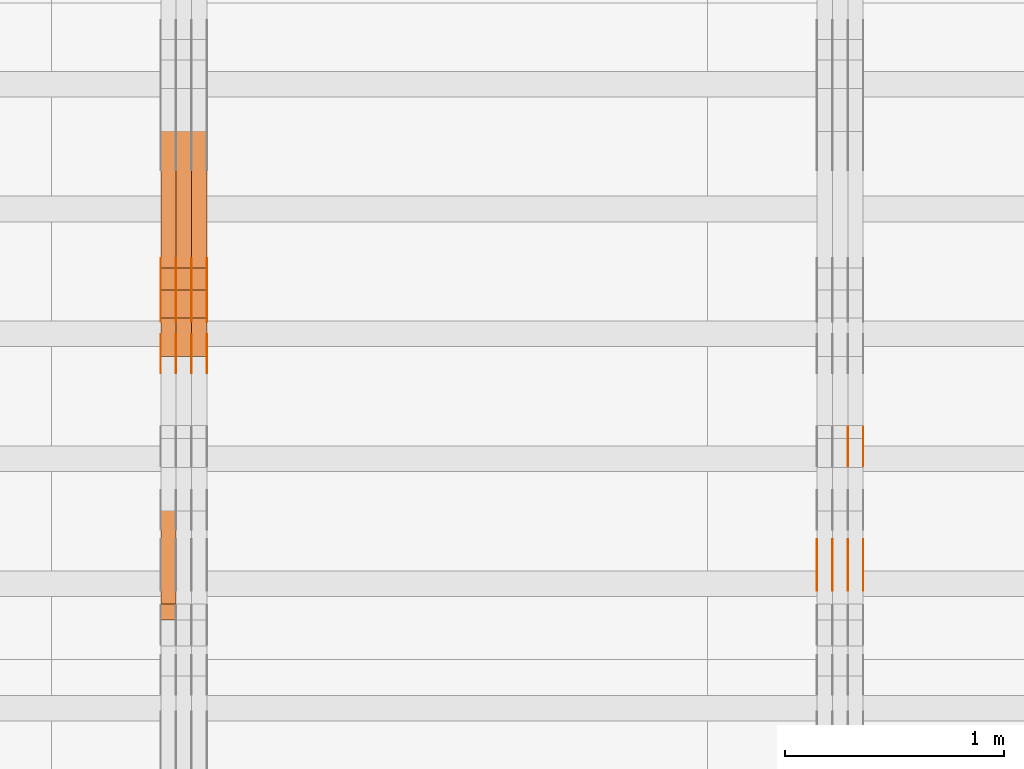
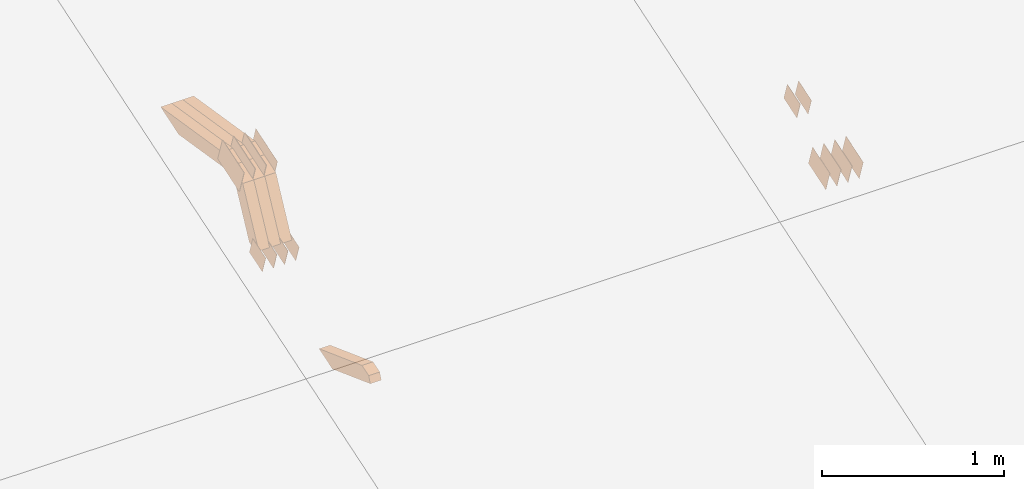
# One storey, part 136 of 385: 28 proxies.
"""IFC2X3 building model written with IfcOpenShell, lengths in millimetres."""

from ifc_helpers import new_model, entity, si_unit, converted_unit, derived_unit, direction, frame, origin, place, context, subcontext, project, spatial, polyline, outline, extrude, source, transform, mapped, material, type_object, type_shapes, element, save


model = new_model("IFC2X3")

# Units and contexts
model_context = context("Model", 3, precision=0.01, world=origin(), true_north=direction((6.12303176911189e-17, 1.0)))
body_context = subcontext(model_context, "Body", "Model", "MODEL_VIEW")
ifc_project = project(units=[si_unit("LENGTHUNIT", "METRE", prefix="MILLI"), si_unit("AREAUNIT", "SQUARE_METRE"), si_unit("VOLUMEUNIT", "CUBIC_METRE"), converted_unit("PLANEANGLEUNIT", "DEGREE", entity("IfcRatioMeasure", 0.0174532925199433), si_unit("PLANEANGLEUNIT", "RADIAN"), dimensions=[0, 0, 0, 0, 0, 0, 0]), si_unit("MASSUNIT", "GRAM", prefix="KILO"), derived_unit("MASSDENSITYUNIT", [(si_unit("MASSUNIT", "GRAM", prefix="KILO"), 1), (si_unit("LENGTHUNIT", "METRE"), -3)]), si_unit("TIMEUNIT", "SECOND"), si_unit("FREQUENCYUNIT", "HERTZ"), si_unit("THERMODYNAMICTEMPERATUREUNIT", "DEGREE_CELSIUS"), derived_unit("THERMALTRANSMITTANCEUNIT", [(si_unit("MASSUNIT", "GRAM", prefix="KILO"), 1), (si_unit("THERMODYNAMICTEMPERATUREUNIT", "KELVIN"), -1), (si_unit("TIMEUNIT", "SECOND"), -3)]), derived_unit("VOLUMETRICFLOWRATEUNIT", [(si_unit("LENGTHUNIT", "METRE"), 3), (si_unit("TIMEUNIT", "SECOND"), -1)]), si_unit("ELECTRICCURRENTUNIT", "AMPERE"), si_unit("ELECTRICVOLTAGEUNIT", "VOLT"), si_unit("POWERUNIT", "WATT"), si_unit("FORCEUNIT", "NEWTON", prefix="KILO"), si_unit("ILLUMINANCEUNIT", "LUX"), si_unit("LUMINOUSFLUXUNIT", "LUMEN"), si_unit("LUMINOUSINTENSITYUNIT", "CANDELA"), derived_unit("USERDEFINED", [(si_unit("MASSUNIT", "GRAM", prefix="KILO"), -1), (si_unit("LENGTHUNIT", "METRE"), -2), (si_unit("TIMEUNIT", "SECOND"), 3), (si_unit("LUMINOUSFLUXUNIT", "LUMEN"), 1)]), derived_unit("LINEARVELOCITYUNIT", [(si_unit("LENGTHUNIT", "METRE"), 1), (si_unit("TIMEUNIT", "SECOND"), -1)]), si_unit("PRESSUREUNIT", "PASCAL"), derived_unit("USERDEFINED", [(si_unit("LENGTHUNIT", "METRE"), -2), (si_unit("MASSUNIT", "GRAM", prefix="KILO"), 1), (si_unit("TIMEUNIT", "SECOND"), -2)])], contexts=[model_context])

# Site, building, storey
site_placement = place(None, origin())
site = spatial("IfcSite", under=ifc_project, at=site_placement, CompositionType="ELEMENT")
building_placement = place(site_placement, origin())
building = spatial("IfcBuilding", under=site, at=building_placement, CompositionType="ELEMENT")
storey_placement = place(building_placement, origin())
storey = spatial("IfcBuildingStorey", under=building, at=storey_placement, Name="Default", CompositionType="ELEMENT", Elevation=0.0)

# Proxies
ifc_material_1 = material(Name="IfcSurfaceStyle #349262")
building_element_proxy_type_1 = type_object("IfcBuildingElementProxyType", PredefinedType="NOTDEFINED", material=ifc_material_1)
shared_shape_1 = source(origin(), body_context, "Body", "SweptSolid", [
    extrude(outline(polyline([(-99.999644645517, -72.0000317581407), (100.000028485991, -72.0000317581407), (99.999644645517, 72.0000317581407), (-100.000028485991, 72.0000317581407), (-99.999644645517, -72.0000317581407)])), frame((100.000028485991, 72.0000317581407, 0.0), z_axis=(0.0, 0.0, 1.0), x_axis=(-1.0, 0.0, 0.0)), (0.0, 0.0, 1.0), 1.3),
])
type_shapes(building_element_proxy_type_1, [shared_shape_1])
proxy_1_placement = place(building_placement, frame((27386.3, 9012.6304394324, 2546.30522609783), z_axis=(-1.0, 0.0, 0.0), x_axis=(0.0, 0.951056516295154, 0.309016994374948)))
element("IfcBuildingElementProxy", 1, at=proxy_1_placement, inside=storey, type_object=building_element_proxy_type_1, material=ifc_material_1, context=body_context, shape_type="MappedRepresentation", body=[
    mapped(shared_shape_1, transform((0.0, 0.0, 0.0), scale=1.0)),
])
ifc_material_2 = material(Name="IfcSurfaceStyle #349205")
building_element_proxy_type_2 = type_object("IfcBuildingElementProxyType", PredefinedType="NOTDEFINED", material=ifc_material_2)
shared_shape_2 = source(origin(), body_context, "Body", "SweptSolid", [
    extrude(outline(polyline([(-99.999644645517, -72.0000317581407), (100.000028485991, -72.0000317581407), (99.999644645517, 72.0000317581407), (-100.000028485991, 72.0000317581407), (-99.999644645517, -72.0000317581407)])), frame((100.000028485991, 72.0000317581407, 0.0), z_axis=(0.0, 0.0, 1.0), x_axis=(-1.0, 0.0, 0.0)), (0.0, 0.0, 1.0), 1.3),
])
type_shapes(building_element_proxy_type_2, [shared_shape_2])
proxy_2_placement = place(building_placement, frame((27315.0, 9012.6304394324, 2546.30522609783), z_axis=(-1.0, 0.0, 0.0), x_axis=(0.0, 0.951056516295154, 0.309016994374948)))
element("IfcBuildingElementProxy", 2, at=proxy_2_placement, inside=storey, type_object=building_element_proxy_type_2, material=ifc_material_2, context=body_context, shape_type="MappedRepresentation", body=[
    mapped(shared_shape_2, transform((0.0, 0.0, 0.0), scale=1.0)),
])
ifc_material_3 = material(Name="IfcSurfaceStyle #349148")
building_element_proxy_type_3 = type_object("IfcBuildingElementProxyType", PredefinedType="NOTDEFINED", material=ifc_material_3)
shared_shape_3 = source(origin(), body_context, "Body", "SweptSolid", [
    extrude(outline(polyline([(-99.999644645517, -72.0000317581407), (100.000028485991, -72.0000317581407), (99.999644645517, 72.0000317581407), (-100.000028485991, 72.0000317581407), (-99.999644645517, -72.0000317581407)])), frame((100.000028485991, 72.0000317581407, 0.0), z_axis=(0.0, 0.0, 1.0), x_axis=(-1.0, 0.0, 0.0)), (0.0, 0.0, 1.0), 1.3),
])
type_shapes(building_element_proxy_type_3, [shared_shape_3])
proxy_3_placement = place(building_placement, frame((27316.3, 9012.6304394324, 2546.30522609783), z_axis=(-1.0, 0.0, 0.0), x_axis=(0.0, 0.951056516295154, 0.309016994374948)))
element("IfcBuildingElementProxy", 3, at=proxy_3_placement, inside=storey, type_object=building_element_proxy_type_3, material=ifc_material_3, context=body_context, shape_type="MappedRepresentation", body=[
    mapped(shared_shape_3, transform((0.0, 0.0, 0.0), scale=1.0)),
])
ifc_material_4 = material(Name="IfcSurfaceStyle #349091")
building_element_proxy_type_4 = type_object("IfcBuildingElementProxyType", PredefinedType="NOTDEFINED", material=ifc_material_4)
shared_shape_4 = source(origin(), body_context, "Body", "SweptSolid", [
    extrude(outline(polyline([(-99.999644645517, -72.0000317581407), (100.000028485991, -72.0000317581407), (99.999644645517, 72.0000317581407), (-100.000028485991, 72.0000317581407), (-99.999644645517, -72.0000317581407)])), frame((100.000028485991, 72.0000317581407, 0.0), z_axis=(0.0, 0.0, 1.0), x_axis=(-1.0, 0.0, 0.0)), (0.0, 0.0, 1.0), 1.29999999999998),
])
type_shapes(building_element_proxy_type_4, [shared_shape_4])
proxy_4_placement = place(building_placement, frame((27245.0, 9012.6304394324, 2546.30522609783), z_axis=(-1.0, 0.0, 0.0), x_axis=(0.0, 0.951056516295154, 0.309016994374948)))
element("IfcBuildingElementProxy", 4, at=proxy_4_placement, inside=storey, type_object=building_element_proxy_type_4, material=ifc_material_4, context=body_context, shape_type="MappedRepresentation", body=[
    mapped(shared_shape_4, transform((0.0, 0.0, 0.0), scale=1.0)),
])
ifc_material_5 = material(Name="IfcSurfaceStyle #349034")
building_element_proxy_type_5 = type_object("IfcBuildingElementProxyType", PredefinedType="NOTDEFINED", material=ifc_material_5)
shared_shape_5 = source(origin(), body_context, "Body", "SweptSolid", [
    extrude(outline(polyline([(-99.999644645517, -72.0000317581407), (100.000028485991, -72.0000317581407), (99.999644645517, 72.0000317581407), (-100.000028485991, 72.0000317581407), (-99.999644645517, -72.0000317581407)])), frame((100.000028485991, 72.0000317581407, 0.0), z_axis=(0.0, 0.0, 1.0), x_axis=(-1.0, 0.0, 0.0)), (0.0, 0.0, 1.0), 1.29999999999998),
])
type_shapes(building_element_proxy_type_5, [shared_shape_5])
proxy_5_placement = place(building_placement, frame((27246.3, 9012.6304394324, 2546.30522609783), z_axis=(-1.0, 0.0, 0.0), x_axis=(0.0, 0.951056516295154, 0.309016994374948)))
element("IfcBuildingElementProxy", 5, at=proxy_5_placement, inside=storey, type_object=building_element_proxy_type_5, material=ifc_material_5, context=body_context, shape_type="MappedRepresentation", body=[
    mapped(shared_shape_5, transform((0.0, 0.0, 0.0), scale=1.0)),
])
ifc_material_6 = material(Name="IfcSurfaceStyle #348977")
building_element_proxy_type_6 = type_object("IfcBuildingElementProxyType", PredefinedType="NOTDEFINED", material=ifc_material_6)
shared_shape_6 = source(origin(), body_context, "Body", "SweptSolid", [
    extrude(outline(polyline([(-99.999644645517, -72.0000317581407), (100.000028485991, -72.0000317581407), (99.999644645517, 72.0000317581407), (-100.000028485991, 72.0000317581407), (-99.999644645517, -72.0000317581407)])), frame((100.000028485991, 72.0000317581407, 0.0), z_axis=(0.0, 0.0, 1.0), x_axis=(-1.0, 0.0, 0.0)), (0.0, 0.0, 1.0), 1.29999999999999),
])
type_shapes(building_element_proxy_type_6, [shared_shape_6])
proxy_6_placement = place(building_placement, frame((27175.0, 9012.6304394324, 2546.30522609783), z_axis=(-1.0, 0.0, 0.0), x_axis=(0.0, 0.951056516295154, 0.309016994374948)))
element("IfcBuildingElementProxy", 6, at=proxy_6_placement, inside=storey, type_object=building_element_proxy_type_6, material=ifc_material_6, context=body_context, shape_type="MappedRepresentation", body=[
    mapped(shared_shape_6, transform((0.0, 0.0, 0.0), scale=1.0)),
])
ifc_material_7 = material(Name="IfcSurfaceStyle #348920")
building_element_proxy_type_7 = type_object("IfcBuildingElementProxyType", PredefinedType="NOTDEFINED", material=ifc_material_7)
shared_shape_7 = source(origin(), body_context, "Body", "SweptSolid", [
    extrude(outline(polyline([(-74.9998754286207, -60.0000016373506), (74.9998605591063, -60.0000016373506), (74.9998754286244, 60.0000016373506), (-74.9998605591099, 60.0000016373506), (-74.9998754286207, -60.0000016373506)])), frame((74.9998754286244, 60.0000016373506, 0.0), z_axis=(0.0, 0.0, 1.0), x_axis=(-1.0, 0.0, 0.0)), (0.0, 0.0, 1.0), 1.3),
])
type_shapes(building_element_proxy_type_7, [shared_shape_7])
proxy_7_placement = place(building_placement, frame((27386.3, 9580.89841427132, 2615.81135078741), z_axis=(-1.0, 0.0, 0.0), x_axis=(0.0, 0.951056516295154, 0.309016994374948)))
element("IfcBuildingElementProxy", 7, at=proxy_7_placement, inside=storey, type_object=building_element_proxy_type_7, material=ifc_material_7, context=body_context, shape_type="MappedRepresentation", body=[
    mapped(shared_shape_7, transform((0.0, 0.0, 0.0), scale=1.0)),
])
ifc_material_8 = material(Name="IfcSurfaceStyle #348863")
building_element_proxy_type_8 = type_object("IfcBuildingElementProxyType", PredefinedType="NOTDEFINED", material=ifc_material_8)
shared_shape_8 = source(origin(), body_context, "Body", "SweptSolid", [
    extrude(outline(polyline([(-74.9998754286207, -60.0000016373506), (74.9998605591063, -60.0000016373506), (74.9998754286244, 60.0000016373506), (-74.9998605591099, 60.0000016373506), (-74.9998754286207, -60.0000016373506)])), frame((74.9998754286244, 60.0000016373506, 0.0), z_axis=(0.0, 0.0, 1.0), x_axis=(-1.0, 0.0, 0.0)), (0.0, 0.0, 1.0), 1.3),
])
type_shapes(building_element_proxy_type_8, [shared_shape_8])
proxy_8_placement = place(building_placement, frame((27315.0, 9580.89841427132, 2615.81135078741), z_axis=(-1.0, 0.0, 0.0), x_axis=(0.0, 0.951056516295154, 0.309016994374948)))
element("IfcBuildingElementProxy", 8, at=proxy_8_placement, inside=storey, type_object=building_element_proxy_type_8, material=ifc_material_8, context=body_context, shape_type="MappedRepresentation", body=[
    mapped(shared_shape_8, transform((0.0, 0.0, 0.0), scale=1.0)),
])
ifc_material_9 = material(Name="IfcSurfaceStyle #348806")
building_element_proxy_type_9 = type_object("IfcBuildingElementProxyType", PredefinedType="NOTDEFINED", material=ifc_material_9)
shared_shape_9 = source(origin(), body_context, "Body", "SweptSolid", [
    extrude(outline(polyline([(-74.9998754286207, -60.0000016373506), (74.9998605591063, -60.0000016373506), (74.9998754286244, 60.0000016373506), (-74.9998605591099, 60.0000016373506), (-74.9998754286207, -60.0000016373506)])), frame((74.9998754286244, 60.0000016373506, 0.0), z_axis=(0.0, 0.0, 1.0), x_axis=(-1.0, 0.0, 0.0)), (0.0, 0.0, 1.0), 1.3),
])
type_shapes(building_element_proxy_type_9, [shared_shape_9])
proxy_9_placement = place(building_placement, frame((27316.3, 9580.89841427132, 2615.81135078741), z_axis=(-1.0, 0.0, 0.0), x_axis=(0.0, 0.951056516295154, 0.309016994374948)))
element("IfcBuildingElementProxy", 9, at=proxy_9_placement, inside=storey, type_object=building_element_proxy_type_9, material=ifc_material_9, context=body_context, shape_type="MappedRepresentation", body=[
    mapped(shared_shape_9, transform((0.0, 0.0, 0.0), scale=1.0)),
])
ifc_material_10 = material(Name="IfcSurfaceStyle #313120")
building_element_proxy_type_10 = type_object("IfcBuildingElementProxyType", PredefinedType="NOTDEFINED", material=ifc_material_10)
shared_shape_10 = source(origin(), body_context, "Body", "SweptSolid", [
    extrude(outline(polyline([(-124.999432723313, -83.9999457831645), (125.000177551971, -83.9999457831645), (124.999395001513, 83.9999457831646), (-125.000139830171, 83.9999457831645), (-124.999432723313, -83.9999457831645)])), frame((125.000177551971, 84.0001194377192, 0.0), z_axis=(0.0, 0.0, 1.0), x_axis=(-1.0, 0.0, 0.0)), (0.0, 0.0, 1.0), 1.3),
])
type_shapes(building_element_proxy_type_10, [shared_shape_10])
proxy_10_placement = place(building_placement, frame((24386.3, 10242.0968435406, 2855.88278137571), z_axis=(-1.0, 0.0, 0.0), x_axis=(0.0, 0.951056516295154, 0.309016994374948)))
element("IfcBuildingElementProxy", 10, at=proxy_10_placement, inside=storey, type_object=building_element_proxy_type_10, material=ifc_material_10, context=body_context, shape_type="MappedRepresentation", body=[
    mapped(shared_shape_10, transform((0.0, 0.0, 0.0), scale=1.0)),
])
ifc_material_11 = material(Name="IfcSurfaceStyle #313063")
building_element_proxy_type_11 = type_object("IfcBuildingElementProxyType", PredefinedType="NOTDEFINED", material=ifc_material_11)
shared_shape_11 = source(origin(), body_context, "Body", "SweptSolid", [
    extrude(outline(polyline([(-124.999432723313, -83.9999457831645), (125.000177551971, -83.9999457831645), (124.999395001513, 83.9999457831646), (-125.000139830171, 83.9999457831645), (-124.999432723313, -83.9999457831645)])), frame((125.000177551971, 84.0001194377192, 0.0), z_axis=(0.0, 0.0, 1.0), x_axis=(-1.0, 0.0, 0.0)), (0.0, 0.0, 1.0), 1.3),
])
type_shapes(building_element_proxy_type_11, [shared_shape_11])
proxy_11_placement = place(building_placement, frame((24315.0, 10242.0968435406, 2855.88278137571), z_axis=(-1.0, 0.0, 0.0), x_axis=(0.0, 0.951056516295154, 0.309016994374948)))
element("IfcBuildingElementProxy", 11, at=proxy_11_placement, inside=storey, type_object=building_element_proxy_type_11, material=ifc_material_11, context=body_context, shape_type="MappedRepresentation", body=[
    mapped(shared_shape_11, transform((0.0, 0.0, 0.0), scale=1.0)),
])
ifc_material_12 = material(Name="IfcSurfaceStyle #313006")
building_element_proxy_type_12 = type_object("IfcBuildingElementProxyType", PredefinedType="NOTDEFINED", material=ifc_material_12)
shared_shape_12 = source(origin(), body_context, "Body", "SweptSolid", [
    extrude(outline(polyline([(-124.999432723313, -83.9999457831645), (125.000177551971, -83.9999457831645), (124.999395001513, 83.9999457831646), (-125.000139830171, 83.9999457831645), (-124.999432723313, -83.9999457831645)])), frame((125.000177551971, 84.0001194377192, 0.0), z_axis=(0.0, 0.0, 1.0), x_axis=(-1.0, 0.0, 0.0)), (0.0, 0.0, 1.0), 1.3),
])
type_shapes(building_element_proxy_type_12, [shared_shape_12])
proxy_12_placement = place(building_placement, frame((24316.3, 10242.0968435406, 2855.88278137571), z_axis=(-1.0, 0.0, 0.0), x_axis=(0.0, 0.951056516295154, 0.309016994374948)))
element("IfcBuildingElementProxy", 12, at=proxy_12_placement, inside=storey, type_object=building_element_proxy_type_12, material=ifc_material_12, context=body_context, shape_type="MappedRepresentation", body=[
    mapped(shared_shape_12, transform((0.0, 0.0, 0.0), scale=1.0)),
])
ifc_material_13 = material(Name="IfcSurfaceStyle #312949")
building_element_proxy_type_13 = type_object("IfcBuildingElementProxyType", PredefinedType="NOTDEFINED", material=ifc_material_13)
shared_shape_13 = source(origin(), body_context, "Body", "SweptSolid", [
    extrude(outline(polyline([(-124.999432723313, -83.9999457831645), (125.000177551971, -83.9999457831645), (124.999395001513, 83.9999457831646), (-125.000139830171, 83.9999457831645), (-124.999432723313, -83.9999457831645)])), frame((125.000177551971, 84.0001194377192, 0.0), z_axis=(0.0, 0.0, 1.0), x_axis=(-1.0, 0.0, 0.0)), (0.0, 0.0, 1.0), 1.29999999999998),
])
type_shapes(building_element_proxy_type_13, [shared_shape_13])
proxy_13_placement = place(building_placement, frame((24245.0, 10242.0968435406, 2855.88278137571), z_axis=(-1.0, 0.0, 0.0), x_axis=(0.0, 0.951056516295154, 0.309016994374948)))
element("IfcBuildingElementProxy", 13, at=proxy_13_placement, inside=storey, type_object=building_element_proxy_type_13, material=ifc_material_13, context=body_context, shape_type="MappedRepresentation", body=[
    mapped(shared_shape_13, transform((0.0, 0.0, 0.0), scale=1.0)),
])
ifc_material_14 = material(Name="IfcSurfaceStyle #312892")
building_element_proxy_type_14 = type_object("IfcBuildingElementProxyType", PredefinedType="NOTDEFINED", material=ifc_material_14)
shared_shape_14 = source(origin(), body_context, "Body", "SweptSolid", [
    extrude(outline(polyline([(-124.999432723313, -83.9999457831645), (125.000177551971, -83.9999457831645), (124.999395001513, 83.9999457831646), (-125.000139830171, 83.9999457831645), (-124.999432723313, -83.9999457831645)])), frame((125.000177551971, 84.0001194377192, 0.0), z_axis=(0.0, 0.0, 1.0), x_axis=(-1.0, 0.0, 0.0)), (0.0, 0.0, 1.0), 1.29999999999998),
])
type_shapes(building_element_proxy_type_14, [shared_shape_14])
proxy_14_placement = place(building_placement, frame((24246.3, 10242.0968435406, 2855.88278137571), z_axis=(-1.0, 0.0, 0.0), x_axis=(0.0, 0.951056516295154, 0.309016994374948)))
element("IfcBuildingElementProxy", 14, at=proxy_14_placement, inside=storey, type_object=building_element_proxy_type_14, material=ifc_material_14, context=body_context, shape_type="MappedRepresentation", body=[
    mapped(shared_shape_14, transform((0.0, 0.0, 0.0), scale=1.0)),
])
ifc_material_15 = material(Name="IfcSurfaceStyle #312835")
building_element_proxy_type_15 = type_object("IfcBuildingElementProxyType", PredefinedType="NOTDEFINED", material=ifc_material_15)
shared_shape_15 = source(origin(), body_context, "Body", "SweptSolid", [
    extrude(outline(polyline([(-124.999432723313, -83.9999457831645), (125.000177551971, -83.9999457831645), (124.999395001513, 83.9999457831646), (-125.000139830171, 83.9999457831645), (-124.999432723313, -83.9999457831645)])), frame((125.000177551971, 84.0001194377192, 0.0), z_axis=(0.0, 0.0, 1.0), x_axis=(-1.0, 0.0, 0.0)), (0.0, 0.0, 1.0), 1.29999999999998),
])
type_shapes(building_element_proxy_type_15, [shared_shape_15])
proxy_15_placement = place(building_placement, frame((24175.0, 10242.0968435406, 2855.88278137571), z_axis=(-1.0, 0.0, 0.0), x_axis=(0.0, 0.951056516295154, 0.309016994374948)))
element("IfcBuildingElementProxy", 15, at=proxy_15_placement, inside=storey, type_object=building_element_proxy_type_15, material=ifc_material_15, context=body_context, shape_type="MappedRepresentation", body=[
    mapped(shared_shape_15, transform((0.0, 0.0, 0.0), scale=1.0)),
])
ifc_material_16 = material(Name="IfcSurfaceStyle #311410")
building_element_proxy_type_16 = type_object("IfcBuildingElementProxyType", PredefinedType="NOTDEFINED", material=ifc_material_16)
shared_shape_16 = source(origin(), body_context, "Body", "SweptSolid", [
    extrude(outline(polyline([(-74.9998754286189, -60.0000016373433), (74.9998605591118, -60.0000016373433), (74.9998754286189, 60.0000016373433), (-74.9998605591118, 60.0000016373433), (-74.9998754286189, -60.0000016373433)])), frame((74.9999131819004, 60.0000016373433, 0.0), z_axis=(0.0, 0.0, 1.0), x_axis=(-1.0, 0.0, 0.0)), (0.0, 0.0, 1.0), 1.3),
])
type_shapes(building_element_proxy_type_16, [shared_shape_16])
proxy_16_placement = place(building_placement, frame((24386.3, 10004.8612689908, 2426.87628052724), z_axis=(-1.0, 0.0, 0.0), x_axis=(0.0, 0.951056516295124, 0.309016994375039)))
element("IfcBuildingElementProxy", 16, at=proxy_16_placement, inside=storey, type_object=building_element_proxy_type_16, material=ifc_material_16, context=body_context, shape_type="MappedRepresentation", body=[
    mapped(shared_shape_16, transform((0.0, 0.0, 0.0), scale=1.0)),
])
ifc_material_17 = material(Name="IfcSurfaceStyle #311353")
building_element_proxy_type_17 = type_object("IfcBuildingElementProxyType", PredefinedType="NOTDEFINED", material=ifc_material_17)
shared_shape_17 = source(origin(), body_context, "Body", "SweptSolid", [
    extrude(outline(polyline([(-74.9998754286189, -60.0000016373433), (74.9998605591118, -60.0000016373433), (74.9998754286189, 60.0000016373433), (-74.9998605591118, 60.0000016373433), (-74.9998754286189, -60.0000016373433)])), frame((74.9999131819004, 60.0000016373433, 0.0), z_axis=(0.0, 0.0, 1.0), x_axis=(-1.0, 0.0, 0.0)), (0.0, 0.0, 1.0), 1.3),
])
type_shapes(building_element_proxy_type_17, [shared_shape_17])
proxy_17_placement = place(building_placement, frame((24315.0, 10004.8612689908, 2426.87628052724), z_axis=(-1.0, 0.0, 0.0), x_axis=(0.0, 0.951056516295124, 0.309016994375039)))
element("IfcBuildingElementProxy", 17, at=proxy_17_placement, inside=storey, type_object=building_element_proxy_type_17, material=ifc_material_17, context=body_context, shape_type="MappedRepresentation", body=[
    mapped(shared_shape_17, transform((0.0, 0.0, 0.0), scale=1.0)),
])
ifc_material_18 = material(Name="IfcSurfaceStyle #311296")
building_element_proxy_type_18 = type_object("IfcBuildingElementProxyType", PredefinedType="NOTDEFINED", material=ifc_material_18)
shared_shape_18 = source(origin(), body_context, "Body", "SweptSolid", [
    extrude(outline(polyline([(-74.9998754286189, -60.0000016373433), (74.9998605591118, -60.0000016373433), (74.9998754286189, 60.0000016373433), (-74.9998605591118, 60.0000016373433), (-74.9998754286189, -60.0000016373433)])), frame((74.9999131819004, 60.0000016373433, 0.0), z_axis=(0.0, 0.0, 1.0), x_axis=(-1.0, 0.0, 0.0)), (0.0, 0.0, 1.0), 1.3),
])
type_shapes(building_element_proxy_type_18, [shared_shape_18])
proxy_18_placement = place(building_placement, frame((24316.3, 10004.8612689908, 2426.87628052724), z_axis=(-1.0, 0.0, 0.0), x_axis=(0.0, 0.951056516295124, 0.309016994375039)))
element("IfcBuildingElementProxy", 18, at=proxy_18_placement, inside=storey, type_object=building_element_proxy_type_18, material=ifc_material_18, context=body_context, shape_type="MappedRepresentation", body=[
    mapped(shared_shape_18, transform((0.0, 0.0, 0.0), scale=1.0)),
])
ifc_material_19 = material(Name="IfcSurfaceStyle #311239")
building_element_proxy_type_19 = type_object("IfcBuildingElementProxyType", PredefinedType="NOTDEFINED", material=ifc_material_19)
shared_shape_19 = source(origin(), body_context, "Body", "SweptSolid", [
    extrude(outline(polyline([(-74.9998754286189, -60.0000016373433), (74.9998605591118, -60.0000016373433), (74.9998754286189, 60.0000016373433), (-74.9998605591118, 60.0000016373433), (-74.9998754286189, -60.0000016373433)])), frame((74.9999131819004, 60.0000016373433, 0.0), z_axis=(0.0, 0.0, 1.0), x_axis=(-1.0, 0.0, 0.0)), (0.0, 0.0, 1.0), 1.29999999999999),
])
type_shapes(building_element_proxy_type_19, [shared_shape_19])
proxy_19_placement = place(building_placement, frame((24245.0, 10004.8612689908, 2426.87628052724), z_axis=(-1.0, 0.0, 0.0), x_axis=(0.0, 0.951056516295124, 0.309016994375039)))
element("IfcBuildingElementProxy", 19, at=proxy_19_placement, inside=storey, type_object=building_element_proxy_type_19, material=ifc_material_19, context=body_context, shape_type="MappedRepresentation", body=[
    mapped(shared_shape_19, transform((0.0, 0.0, 0.0), scale=1.0)),
])
ifc_material_20 = material(Name="IfcSurfaceStyle #311182")
building_element_proxy_type_20 = type_object("IfcBuildingElementProxyType", PredefinedType="NOTDEFINED", material=ifc_material_20)
shared_shape_20 = source(origin(), body_context, "Body", "SweptSolid", [
    extrude(outline(polyline([(-74.9998754286189, -60.0000016373433), (74.9998605591118, -60.0000016373433), (74.9998754286189, 60.0000016373433), (-74.9998605591118, 60.0000016373433), (-74.9998754286189, -60.0000016373433)])), frame((74.9999131819004, 60.0000016373433, 0.0), z_axis=(0.0, 0.0, 1.0), x_axis=(-1.0, 0.0, 0.0)), (0.0, 0.0, 1.0), 1.29999999999999),
])
type_shapes(building_element_proxy_type_20, [shared_shape_20])
proxy_20_placement = place(building_placement, frame((24246.3, 10004.8612689908, 2426.87628052724), z_axis=(-1.0, 0.0, 0.0), x_axis=(0.0, 0.951056516295124, 0.309016994375039)))
element("IfcBuildingElementProxy", 20, at=proxy_20_placement, inside=storey, type_object=building_element_proxy_type_20, material=ifc_material_20, context=body_context, shape_type="MappedRepresentation", body=[
    mapped(shared_shape_20, transform((0.0, 0.0, 0.0), scale=1.0)),
])
ifc_material_21 = material(Name="IfcSurfaceStyle #311125")
building_element_proxy_type_21 = type_object("IfcBuildingElementProxyType", PredefinedType="NOTDEFINED", material=ifc_material_21)
shared_shape_21 = source(origin(), body_context, "Body", "SweptSolid", [
    extrude(outline(polyline([(-74.9998754286189, -60.0000016373433), (74.9998605591118, -60.0000016373433), (74.9998754286189, 60.0000016373433), (-74.9998605591118, 60.0000016373433), (-74.9998754286189, -60.0000016373433)])), frame((74.9999131819004, 60.0000016373433, 0.0), z_axis=(0.0, 0.0, 1.0), x_axis=(-1.0, 0.0, 0.0)), (0.0, 0.0, 1.0), 1.29999999999999),
])
type_shapes(building_element_proxy_type_21, [shared_shape_21])
proxy_21_placement = place(building_placement, frame((24175.0, 10004.8612689908, 2426.87628052724), z_axis=(-1.0, 0.0, 0.0), x_axis=(0.0, 0.951056516295124, 0.309016994375039)))
element("IfcBuildingElementProxy", 21, at=proxy_21_placement, inside=storey, type_object=building_element_proxy_type_21, material=ifc_material_21, context=body_context, shape_type="MappedRepresentation", body=[
    mapped(shared_shape_21, transform((0.0, 0.0, 0.0), scale=1.0)),
])
ifc_material_22 = material(Name="IfcSurfaceStyle #291088")
building_element_proxy_type_22 = type_object("IfcBuildingElementProxyType", Name="T1-W5 291086", PredefinedType="NOTDEFINED", material=ifc_material_22)
shared_shape_22 = source(origin(), body_context, "Body", "SweptSolid", [
    extrude(outline(polyline([(-301.214270081322, -47.5000783565111), (303.980395954293, -47.5000783565111), (288.664123931657, 0.000197935560590153), (195.704076557203, 47.4999793887309), (-487.134326361831, 47.4999793887309), (-301.214270081322, -47.5000783565111)])), frame((303.980395954293, 47.5001815410909, 0.0), z_axis=(0.0, 0.0, 1.0), x_axis=(-1.0, 0.0, 0.0)), (0.0, 0.0, 1.0), 70.0),
])
type_shapes(building_element_proxy_type_22, [shared_shape_22])
proxy_22_placement = place(building_placement, frame((24385.0, 10379.2051671398, 2863.91176079486), z_axis=(-1.0, 0.0, 0.0), x_axis=(0.0, 0.987508363398486, -0.1575665961365)))
element("IfcBuildingElementProxy", 22, at=proxy_22_placement, inside=storey, type_object=building_element_proxy_type_22, material=ifc_material_22, Name="T1-W5", context=body_context, shape_type="MappedRepresentation", body=[
    mapped(shared_shape_22, transform((0.0, 0.0, 0.0), scale=1.0)),
])
ifc_material_23 = material(Name="IfcSurfaceStyle #291022")
building_element_proxy_type_23 = type_object("IfcBuildingElementProxyType", Name="T1-W5 291020", PredefinedType="NOTDEFINED", material=ifc_material_23)
shared_shape_23 = source(origin(), body_context, "Body", "SweptSolid", [
    extrude(outline(polyline([(-301.214270081322, -47.5000783565111), (303.980395954293, -47.5000783565111), (288.664123931657, 0.000197935560590153), (195.704076557203, 47.4999793887309), (-487.134326361831, 47.4999793887309), (-301.214270081322, -47.5000783565111)])), frame((303.980395954293, 47.5001815410909, 0.0), z_axis=(0.0, 0.0, 1.0), x_axis=(-1.0, 0.0, 0.0)), (0.0, 0.0, 1.0), 70.0),
])
type_shapes(building_element_proxy_type_23, [shared_shape_23])
proxy_23_placement = place(building_placement, frame((24315.0, 10379.2051671398, 2863.91176079486), z_axis=(-1.0, 0.0, 0.0), x_axis=(0.0, 0.987508363398486, -0.1575665961365)))
element("IfcBuildingElementProxy", 23, at=proxy_23_placement, inside=storey, type_object=building_element_proxy_type_23, material=ifc_material_23, Name="T1-W5", context=body_context, shape_type="MappedRepresentation", body=[
    mapped(shared_shape_23, transform((0.0, 0.0, 0.0), scale=1.0)),
])
ifc_material_24 = material(Name="IfcSurfaceStyle #290956")
building_element_proxy_type_24 = type_object("IfcBuildingElementProxyType", Name="T1-W5 290954", PredefinedType="NOTDEFINED", material=ifc_material_24)
shared_shape_24 = source(origin(), body_context, "Body", "SweptSolid", [
    extrude(outline(polyline([(-301.214270081322, -47.5000783565111), (303.980395954293, -47.5000783565111), (288.664123931657, 0.000197935560590153), (195.704076557203, 47.4999793887309), (-487.134326361831, 47.4999793887309), (-301.214270081322, -47.5000783565111)])), frame((303.980395954293, 47.5001815410909, 0.0), z_axis=(0.0, 0.0, 1.0), x_axis=(-1.0, 0.0, 0.0)), (0.0, 0.0, 1.0), 70.0),
])
type_shapes(building_element_proxy_type_24, [shared_shape_24])
proxy_24_placement = place(building_placement, frame((24245.0, 10379.2051671398, 2863.91176079486), z_axis=(-1.0, 0.0, 0.0), x_axis=(0.0, 0.987508363398486, -0.1575665961365)))
element("IfcBuildingElementProxy", 24, at=proxy_24_placement, inside=storey, type_object=building_element_proxy_type_24, material=ifc_material_24, Name="T1-W5", context=body_context, shape_type="MappedRepresentation", body=[
    mapped(shared_shape_24, transform((0.0, 0.0, 0.0), scale=1.0)),
])
ifc_material_25 = material(Name="IfcSurfaceStyle #290692")
building_element_proxy_type_25 = type_object("IfcBuildingElementProxyType", Name="T1-W37 290690", PredefinedType="NOTDEFINED", material=ifc_material_25)
shared_shape_25 = source(origin(), body_context, "Body", "SweptSolid", [
    extrude(outline(polyline([(111.787482004227, -179.289397746839), (245.990585035629, -179.289397746839), (-64.0177573255029, 131.410401861866), (-131.116409377007, 131.410958895698), (-162.643900337347, 95.757434736113), (111.787482004227, -179.289397746839)])), frame((185.635323570343, 47.5011799885346, 0.0), z_axis=(0.0, 0.0, 1.0), x_axis=(0.706316677358935, 0.707896003156279, 0.0)), (0.0, 0.0, 1.0), 70.0),
])
type_shapes(building_element_proxy_type_25, [shared_shape_25])
proxy_25_placement = place(building_placement, frame((24385.0, 10081.8581176196, 2424.08390440728), z_axis=(-1.0, 0.0, 0.0), x_axis=(0.0, 0.452995827831714, 0.891512635898707)))
element("IfcBuildingElementProxy", 25, at=proxy_25_placement, inside=storey, type_object=building_element_proxy_type_25, material=ifc_material_25, Name="T1-W37", context=body_context, shape_type="MappedRepresentation", body=[
    mapped(shared_shape_25, transform((0.0, 0.0, 0.0), scale=1.0)),
])
ifc_material_26 = material(Name="IfcSurfaceStyle #290626")
building_element_proxy_type_26 = type_object("IfcBuildingElementProxyType", Name="T1-W37 290624", PredefinedType="NOTDEFINED", material=ifc_material_26)
shared_shape_26 = source(origin(), body_context, "Body", "SweptSolid", [
    extrude(outline(polyline([(111.787482004227, -179.289397746839), (245.990585035629, -179.289397746839), (-64.0177573255029, 131.410401861866), (-131.116409377007, 131.410958895698), (-162.643900337347, 95.757434736113), (111.787482004227, -179.289397746839)])), frame((185.635323570343, 47.5011799885346, 0.0), z_axis=(0.0, 0.0, 1.0), x_axis=(0.706316677358935, 0.707896003156279, 0.0)), (0.0, 0.0, 1.0), 70.0),
])
type_shapes(building_element_proxy_type_26, [shared_shape_26])
proxy_26_placement = place(building_placement, frame((24315.0, 10081.8581176196, 2424.08390440728), z_axis=(-1.0, 0.0, 0.0), x_axis=(0.0, 0.452995827831714, 0.891512635898707)))
element("IfcBuildingElementProxy", 26, at=proxy_26_placement, inside=storey, type_object=building_element_proxy_type_26, material=ifc_material_26, Name="T1-W37", context=body_context, shape_type="MappedRepresentation", body=[
    mapped(shared_shape_26, transform((0.0, 0.0, 0.0), scale=1.0)),
])
ifc_material_27 = material(Name="IfcSurfaceStyle #290560")
building_element_proxy_type_27 = type_object("IfcBuildingElementProxyType", Name="T1-W37 290558", PredefinedType="NOTDEFINED", material=ifc_material_27)
shared_shape_27 = source(origin(), body_context, "Body", "SweptSolid", [
    extrude(outline(polyline([(111.787482004227, -179.289397746839), (245.990585035629, -179.289397746839), (-64.0177573255029, 131.410401861866), (-131.116409377007, 131.410958895698), (-162.643900337347, 95.757434736113), (111.787482004227, -179.289397746839)])), frame((185.635323570343, 47.5011799885346, 0.0), z_axis=(0.0, 0.0, 1.0), x_axis=(0.706316677358935, 0.707896003156279, 0.0)), (0.0, 0.0, 1.0), 70.0),
])
type_shapes(building_element_proxy_type_27, [shared_shape_27])
proxy_27_placement = place(building_placement, frame((24245.0, 10081.8581176196, 2424.08390440728), z_axis=(-1.0, 0.0, 0.0), x_axis=(0.0, 0.452995827831714, 0.891512635898707)))
element("IfcBuildingElementProxy", 27, at=proxy_27_placement, inside=storey, type_object=building_element_proxy_type_27, material=ifc_material_27, Name="T1-W37", context=body_context, shape_type="MappedRepresentation", body=[
    mapped(shared_shape_27, transform((0.0, 0.0, 0.0), scale=1.0)),
])
ifc_material_28 = material(Name="IfcSurfaceStyle #289372")
building_element_proxy_type_28 = type_object("IfcBuildingElementProxyType", Name="T1-W25 289370", PredefinedType="NOTDEFINED", material=ifc_material_28)
shared_shape_28 = source(origin(), body_context, "Body", "SweptSolid", [
    extrude(outline(polyline([(-229.232772462784, -47.5001671709529), (214.075939394384, -47.5001671709529), (212.688957821661, -0.000141058964427199), (152.358910178478, 47.5002377004352), (-349.891034931738, 47.5002377004352), (-229.232772462784, -47.5001671709529)])), frame((214.075939394384, 47.5002377004352, 0.0), z_axis=(0.0, 0.0, 1.0), x_axis=(-1.0, 0.0, 0.0)), (0.0, 0.0, 1.0), 70.0),
])
type_shapes(building_element_proxy_type_28, [shared_shape_28])
proxy_28_placement = place(building_placement, frame((24245.0, 8892.81895960242, 2369.29665807578), z_axis=(-1.0, 0.0, 0.0), x_axis=(0.0, 0.938402514401222, -0.345544094097213)))
element("IfcBuildingElementProxy", 28, at=proxy_28_placement, inside=storey, type_object=building_element_proxy_type_28, material=ifc_material_28, Name="T1-W25", context=body_context, shape_type="MappedRepresentation", body=[
    mapped(shared_shape_28, transform((0.0, 0.0, 0.0), scale=1.0)),
])

save(model, "model.ifc")
